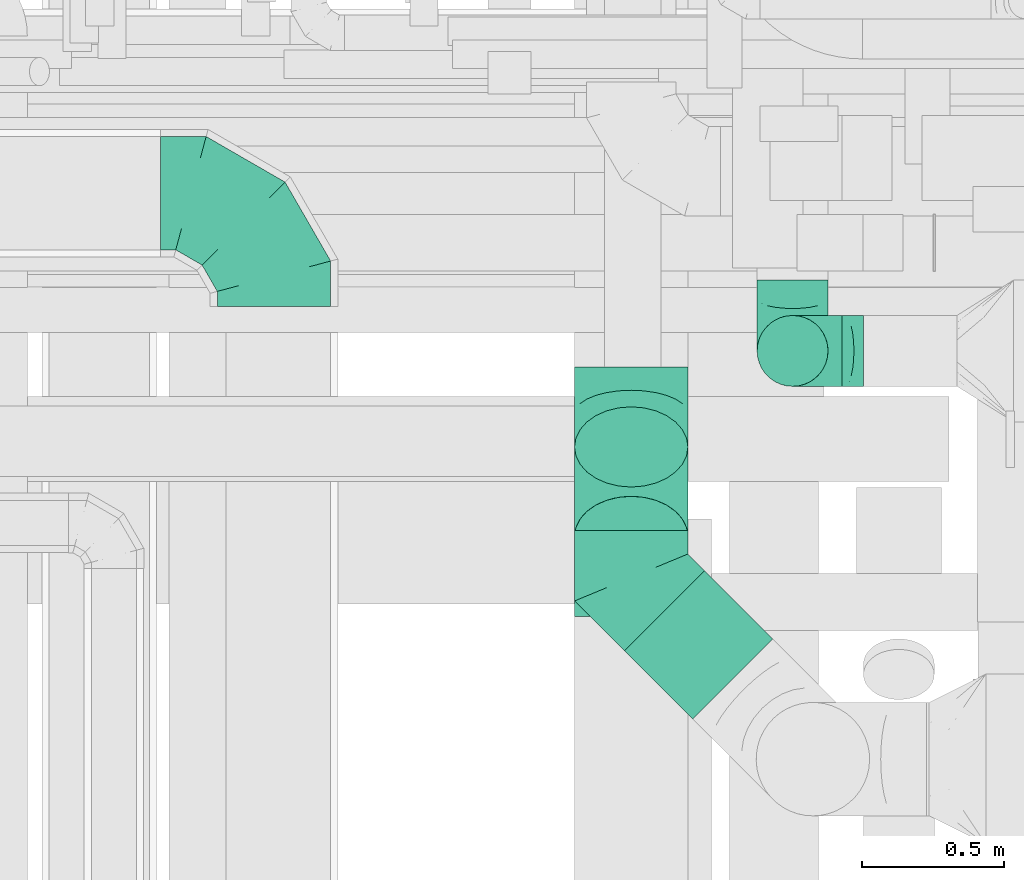
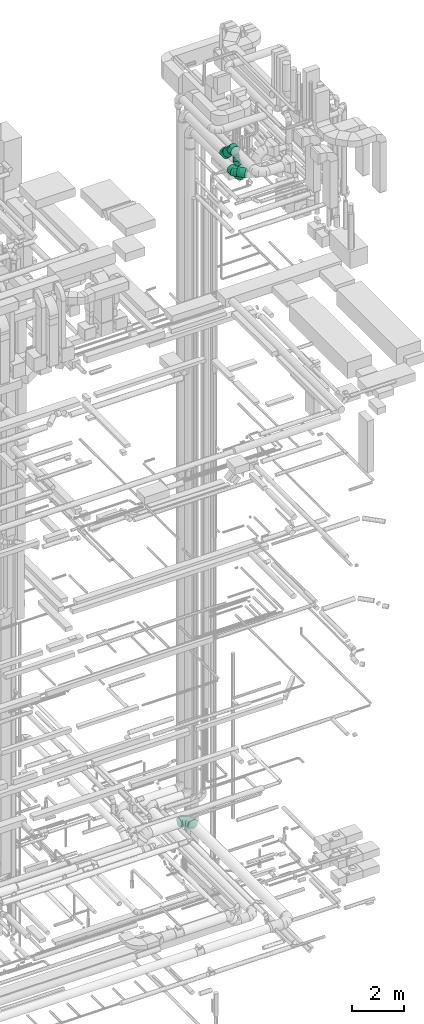
# One storey, part 257 of 337: 7 flow fittings, 4 flow segments.
"""IFC2X3 building model written with IfcOpenShell, lengths in millimetres."""

from ifc_helpers import new_model, entity, si_unit, converted_unit, derived_unit, direction, frame, origin, origin_2d_with_axis, place, context, subcontext, project, spatial, circle, extrude, faceted_brep, source, transform, mapped, material, type_object, type_shapes, element, save


model = new_model("IFC2X3")

# Units and contexts
model_context = context("Model", 3, precision=0.01, world=origin(), true_north=direction((6.12303176911189e-17, 1.0)))
body_context = subcontext(model_context, "Body", "Model", "MODEL_VIEW")
ifc_project = project(units=[si_unit("LENGTHUNIT", "METRE", prefix="MILLI"), si_unit("AREAUNIT", "SQUARE_METRE"), si_unit("VOLUMEUNIT", "CUBIC_METRE"), converted_unit("PLANEANGLEUNIT", "DEGREE", entity("IfcRatioMeasure", 0.0174532925199433), si_unit("PLANEANGLEUNIT", "RADIAN"), dimensions=[0, 0, 0, 0, 0, 0, 0]), si_unit("MASSUNIT", "GRAM", prefix="KILO"), derived_unit("MASSDENSITYUNIT", [(si_unit("MASSUNIT", "GRAM", prefix="KILO"), 1), (si_unit("LENGTHUNIT", "METRE"), -3)]), derived_unit("MOMENTOFINERTIAUNIT", [(si_unit("LENGTHUNIT", "METRE"), 4)]), si_unit("TIMEUNIT", "SECOND"), si_unit("FREQUENCYUNIT", "HERTZ"), si_unit("THERMODYNAMICTEMPERATUREUNIT", "DEGREE_CELSIUS"), derived_unit("THERMALTRANSMITTANCEUNIT", [(si_unit("MASSUNIT", "GRAM", prefix="KILO"), 1), (si_unit("THERMODYNAMICTEMPERATUREUNIT", "KELVIN"), -1), (si_unit("TIMEUNIT", "SECOND"), -3)]), derived_unit("VOLUMETRICFLOWRATEUNIT", [(si_unit("LENGTHUNIT", "METRE"), 3), (si_unit("TIMEUNIT", "SECOND"), -1)]), derived_unit("MASSFLOWRATEUNIT", [(si_unit("MASSUNIT", "GRAM", prefix="KILO"), 1), (si_unit("TIMEUNIT", "SECOND"), -1)]), derived_unit("ROTATIONALFREQUENCYUNIT", [(si_unit("TIMEUNIT", "SECOND"), -1)]), si_unit("ELECTRICCURRENTUNIT", "AMPERE"), si_unit("ELECTRICVOLTAGEUNIT", "VOLT"), si_unit("POWERUNIT", "WATT"), si_unit("FORCEUNIT", "NEWTON", prefix="KILO"), si_unit("ILLUMINANCEUNIT", "LUX"), si_unit("LUMINOUSFLUXUNIT", "LUMEN"), si_unit("LUMINOUSINTENSITYUNIT", "CANDELA"), derived_unit("USERDEFINED", [(si_unit("MASSUNIT", "GRAM", prefix="KILO"), -1), (si_unit("LENGTHUNIT", "METRE"), -2), (si_unit("TIMEUNIT", "SECOND"), 3), (si_unit("LUMINOUSFLUXUNIT", "LUMEN"), 1)]), derived_unit("LINEARVELOCITYUNIT", [(si_unit("LENGTHUNIT", "METRE"), 1), (si_unit("TIMEUNIT", "SECOND"), -1)]), si_unit("PRESSUREUNIT", "PASCAL"), derived_unit("USERDEFINED", [(si_unit("LENGTHUNIT", "METRE"), -2), (si_unit("MASSUNIT", "GRAM", prefix="KILO"), 1), (si_unit("TIMEUNIT", "SECOND"), -2)]), derived_unit("LINEARFORCEUNIT", [(si_unit("MASSUNIT", "GRAM", prefix="KILO"), 1), (si_unit("LENGTHUNIT", "METRE"), 1), (si_unit("TIMEUNIT", "SECOND"), -2), (si_unit("LENGTHUNIT", "METRE"), -1)]), derived_unit("PLANARFORCEUNIT", [(si_unit("MASSUNIT", "GRAM", prefix="KILO"), 1), (si_unit("LENGTHUNIT", "METRE"), 1), (si_unit("TIMEUNIT", "SECOND"), -2), (si_unit("LENGTHUNIT", "METRE"), -2)])], contexts=[model_context])

# Site, building, storey
site_placement = place(None, origin())
site = spatial("IfcSite", under=ifc_project, at=site_placement, CompositionType="ELEMENT")
building_placement = place(site_placement, origin())
building = spatial("IfcBuilding", under=site, at=building_placement, CompositionType="ELEMENT")
storey_placement = place(building_placement, origin())
storey = spatial("IfcBuildingStorey", under=building, at=storey_placement, CompositionType="ELEMENT", Elevation=0.0)

# Flow segments
duct_segment_type = type_object("IfcDuctSegmentType", PredefinedType="NOTDEFINED")
flow_segment_1_placement = place(storey_placement, frame((67357.46, 8396.28, 34974.14)))
element("IfcFlowSegment", 1, at=flow_segment_1_placement, inside=storey, type_object=duct_segment_type, context=body_context, shape_type="SweptSolid", body=[
    extrude(circle(Radius=200.0, at=origin_2d_with_axis()), frame((201.6, 143.02, 458.7), z_axis=(0.0, 0.707106781186547, -0.707106781186548), x_axis=(-1.0, 0.0, 0.0)), (0.0, 0.0, 1.0), 446.44660940674),
])
flow_segment_2_placement = place(storey_placement, frame((67533.19, 7893.55, 34318.4)))
element("IfcFlowSegment", 2, at=flow_segment_2_placement, inside=storey, type_object=duct_segment_type, context=body_context, shape_type="SweptSolid", body=[
    extrude(circle(Radius=200.0, at=origin_2d_with_axis()), frame((143.02, 383.81, 201.6), z_axis=(0.707106781186543, -0.707106781186552, 0.0), x_axis=(0.707106781186552, 0.707106781186543, 0.0)), (0.0, 0.0, 1.0), 340.528682794611),
])
flow_segment_3_placement = place(storey_placement, frame((68001.5, 9067.1, 33750.0)))
element("IfcFlowSegment", 3, at=flow_segment_3_placement, inside=storey, type_object=duct_segment_type, context=body_context, shape_type="SweptSolid", body=[
    extrude(circle(Radius=125.0, at=origin_2d_with_axis()), frame((126.6, 126.6, 0.0), z_axis=(0.0, 0.0, 1.0), x_axis=(0.0, 1.0, 0.0)), (0.0, 0.0, 1.0), 275.000000000041),
])
flow_segment_4_placement = place(storey_placement, frame((68001.5, 9067.1, 34375.0)))
element("IfcFlowSegment", 4, at=flow_segment_4_placement, inside=storey, type_object=duct_segment_type, context=body_context, shape_type="SweptSolid", body=[
    extrude(circle(Radius=125.0, at=origin_2d_with_axis()), frame((126.6, 126.6, 0.0)), (0.0, 0.0, 1.0), 174.999999999995),
])

# Flow fittings
ifc_material = material()
duct_fitting_type_1 = type_object("IfcDuctFittingType", PredefinedType="NOTDEFINED", material=ifc_material)
shared_shape_1 = source(origin(), body_context, "Body", "Brep", [
    faceted_brep([(-250.0, 0.0, -125.0), (-250.0, -32.35, -120.74), (-250.0, -62.5, -108.25), (-250.0, -88.39, -88.39), (-250.0, -108.25, -62.5), (-250.0, -120.74, -32.35), (-250.0, -125.0, 0.0), (-250.0, -120.74, 32.35), (-250.0, -108.25, 62.5), (-250.0, -88.39, 88.39), (-250.0, -62.5, 108.25), (-250.0, -32.35, 120.74), (-250.0, 0.0, 125.0), (-250.0, 32.35, 120.74), (-250.0, 62.5, 108.25), (-250.0, 88.39, 88.39), (-250.0, 108.25, 62.5), (-250.0, 120.74, 32.35), (-250.0, 125.0, 0.0), (-250.0, 120.74, -32.35), (-250.0, 108.25, -62.5), (-250.0, 88.39, -88.39), (-250.0, 62.5, -108.25), (-250.0, 32.35, -120.74), (-191.68, 32.35, 120.74), (-199.76, 62.5, 108.25), (-183.01, 0.0, 125.0), (-206.7, 88.39, 88.39), (-215.37, 120.74, 32.35), (-216.51, 125.0, 0.0), (-212.02, 108.25, 62.5), (-212.02, 108.25, -62.5), (-206.7, 88.39, -88.39), (-215.37, 120.74, -32.35), (-191.68, 32.35, -120.74), (-183.01, 0.0, -125.0), (-199.76, 62.5, -108.25), (-174.34, -32.35, -120.74), (-166.27, -62.5, -108.25), (-159.33, -88.39, -88.39), (-154.01, -108.25, -62.5), (-150.66, -120.74, -32.35), (-149.52, -125.0, 0.0), (-150.66, -120.74, 32.35), (-154.01, -108.25, 62.5), (-159.33, -88.39, 88.39), (-166.27, -62.5, 108.25), (-174.34, -32.35, 120.74), (-90.67, 90.67, 120.74), (-112.74, 112.74, 108.25), (-66.99, 66.99, 125.0), (-131.69, 131.69, 88.39), (-146.23, 146.23, 62.5), (-155.38, 155.38, 32.35), (-158.49, 158.49, 0.0), (-155.38, 155.38, -32.35), (-146.23, 146.23, -62.5), (-131.69, 131.69, -88.39), (-90.67, 90.67, -120.74), (-66.99, 66.99, -125.0), (-112.74, 112.74, -108.25), (-43.3, 43.3, -120.74), (-21.23, 21.23, -108.25), (-2.28, 2.28, -88.39), (12.26, -12.26, -62.5), (21.4, -21.4, -32.35), (24.52, -24.52, 0.0), (21.4, -21.4, 32.35), (12.26, -12.26, 62.5), (-2.28, 2.28, 88.39), (-21.23, 21.23, 108.25), (-43.3, 43.3, 120.74), (-32.35, 191.68, 120.74), (-62.5, 199.76, 108.25), (0.0, 183.01, 125.0), (-88.39, 206.7, 88.39), (-108.25, 212.02, 62.5), (-120.74, 215.37, 32.35), (-125.0, 216.51, 0.0), (-120.74, 215.37, -32.35), (-108.25, 212.02, -62.5), (-88.39, 206.7, -88.39), (-32.35, 191.68, -120.74), (0.0, 183.01, -125.0), (-62.5, 199.76, -108.25), (32.35, 174.34, -120.74), (62.5, 166.27, -108.25), (88.39, 159.33, -88.39), (108.25, 154.01, -62.5), (120.74, 150.66, -32.35), (125.0, 149.52, 0.0), (120.74, 150.66, 32.35), (108.25, 154.01, 62.5), (88.39, 159.33, 88.39), (62.5, 166.27, 108.25), (32.35, 174.34, 120.74), (-32.35, 250.0, -120.74), (-62.5, 250.0, -108.25), (-88.39, 250.0, -88.39), (-108.25, 250.0, -62.5), (-120.74, 250.0, -32.35), (-125.0, 250.0, 0.0), (-120.74, 250.0, 32.35), (-108.25, 250.0, 62.5), (-88.39, 250.0, 88.39), (-62.5, 250.0, 108.25), (-32.35, 250.0, 120.74), (0.0, 250.0, 125.0), (32.35, 250.0, 120.74), (62.5, 250.0, 108.25), (88.39, 250.0, 88.39), (108.25, 250.0, 62.5), (120.74, 250.0, 32.35), (125.0, 250.0, 0.0), (120.74, 250.0, -32.35), (108.25, 250.0, -62.5), (88.39, 250.0, -88.39), (62.5, 250.0, -108.25), (32.35, 250.0, -120.74), (0.0, 250.0, -125.0)], [[[0, 1, 2, 3, 4, 5, 6, 7, 8, 9, 10, 11, 12, 13, 14, 15, 16, 17, 18, 19, 20, 21, 22, 23]], [[24, 25, 14, 13]], [[26, 24, 13, 12]], [[14, 25, 27, 15]], [[28, 29, 18, 17]], [[30, 28, 17, 16]], [[15, 27, 30, 16]], [[20, 31, 32, 21]], [[33, 31, 20, 19]], [[18, 29, 33, 19]], [[34, 35, 0, 23]], [[36, 34, 23, 22]], [[21, 32, 36, 22]], [[1, 0, 35, 37]], [[2, 1, 37, 38]], [[38, 39, 3, 2]], [[5, 4, 40, 41]], [[6, 5, 41, 42]], [[39, 40, 4, 3]], [[6, 42, 43, 7]], [[7, 43, 44, 8]], [[8, 44, 45, 9]], [[9, 45, 46, 10]], [[10, 46, 47, 11]], [[26, 12, 11, 47]], [[48, 49, 25, 24]], [[50, 48, 24, 26]], [[27, 25, 49, 51]], [[52, 53, 28, 30]], [[51, 52, 30, 27]], [[29, 28, 53, 54]], [[55, 56, 31, 33]], [[54, 55, 33, 29]], [[32, 31, 56, 57]], [[58, 59, 35, 34]], [[60, 58, 34, 36]], [[57, 60, 36, 32]], [[37, 35, 59, 61]], [[38, 37, 61, 62]], [[39, 38, 62, 63]], [[41, 40, 64, 65]], [[42, 41, 65, 66]], [[63, 64, 40, 39]], [[43, 42, 66, 67]], [[44, 43, 67, 68]], [[68, 69, 45, 44]], [[46, 45, 69, 70]], [[47, 46, 70, 71]], [[26, 47, 71, 50]], [[72, 73, 49, 48]], [[74, 72, 48, 50]], [[51, 49, 73, 75]], [[76, 77, 53, 52]], [[75, 76, 52, 51]], [[54, 53, 77, 78]], [[79, 80, 56, 55]], [[78, 79, 55, 54]], [[57, 56, 80, 81]], [[82, 83, 59, 58]], [[84, 82, 58, 60]], [[81, 84, 60, 57]], [[61, 59, 83, 85]], [[62, 61, 85, 86]], [[63, 62, 86, 87]], [[65, 64, 88, 89]], [[66, 65, 89, 90]], [[87, 88, 64, 63]], [[67, 66, 90, 91]], [[68, 67, 91, 92]], [[92, 93, 69, 68]], [[70, 69, 93, 94]], [[71, 70, 94, 95]], [[50, 71, 95, 74]], [[96, 97, 98, 99, 100, 101, 102, 103, 104, 105, 106, 107, 108, 109, 110, 111, 112, 113, 114, 115, 116, 117, 118, 119]], [[72, 74, 107, 106]], [[73, 72, 106, 105]], [[75, 73, 105, 104]], [[77, 76, 103, 102]], [[78, 77, 102, 101]], [[75, 104, 103, 76]], [[78, 101, 100, 79]], [[79, 100, 99, 80]], [[80, 99, 98, 81]], [[84, 97, 96, 82]], [[82, 96, 119, 83]], [[84, 81, 98, 97]], [[83, 119, 118, 85]], [[85, 118, 117, 86]], [[116, 87, 86, 117]], [[88, 115, 114, 89]], [[89, 114, 113, 90]], [[115, 88, 87, 116]], [[91, 90, 113, 112]], [[92, 91, 112, 111]], [[111, 110, 93, 92]], [[95, 94, 109, 108]], [[74, 95, 108, 107]], [[110, 109, 94, 93]]]),
])
type_shapes(duct_fitting_type_1, [shared_shape_1])
for number, where, z_axis, x_axis in (
    (5, (68128.1, 9193.7, 33500.0), (0.0, 1.0, 0.0), (-1.0, 0.0, 0.0)),
    (6, (68128.1, 9193.7, 34800.0), (-1.0, 0.0, 0.0), (0.0, 0.0, 1.0)),
):
    element("IfcFlowFitting", number, at=place(storey_placement, frame(where, z_axis=z_axis, x_axis=x_axis)), inside=storey, type_object=duct_fitting_type_1, material=ifc_material, context=body_context, shape_type="MappedRepresentation", body=[
        mapped(shared_shape_1, transform((0.0, 0.0, 0.0), scale=1.0)),
    ])
duct_fitting_type_2 = type_object("IfcDuctFittingType", PredefinedType="NOTDEFINED", material=ifc_material)
shared_shape_2 = source(origin(), body_context, "Body", "Brep", [
    faceted_brep([(-165.69, 0.0, -200.0), (-165.69, -44.5, -194.99), (-165.69, -86.78, -180.19), (-165.69, -124.7, -156.37), (-165.69, -156.37, -124.7), (-165.69, -180.19, -86.78), (-165.69, -194.99, -44.5), (-165.69, -200.0, 0.0), (-165.69, -194.99, 44.5), (-165.69, -180.19, 86.78), (-165.69, -156.37, 124.7), (-165.69, -124.7, 156.37), (-165.69, -86.78, 180.19), (-165.69, -44.5, 194.99), (-165.69, 0.0, 200.0), (-165.69, 44.5, 194.99), (-165.69, 86.78, 180.19), (-165.69, 124.7, 156.37), (-165.69, 156.37, 124.7), (-165.69, 180.19, 86.78), (-165.69, 194.99, 44.5), (-165.69, 200.0, 0.0), (-165.69, 194.99, -44.5), (-165.69, 180.19, -86.78), (-165.69, 156.37, -124.7), (-165.69, 124.7, -156.37), (-165.69, 86.78, -180.19), (-165.69, 44.5, -194.99), (0.0, 0.0, 200.0), (-18.43, 44.5, 194.99), (-35.94, 86.78, 180.19), (-51.65, 124.7, 156.37), (-64.77, 156.37, 124.7), (-74.64, 180.19, 86.78), (-80.77, 194.99, 44.5), (-82.84, 200.0, 0.0), (-80.77, 194.99, -44.5), (-74.64, 180.19, -86.78), (-64.77, 156.37, -124.7), (-51.65, 124.7, -156.37), (-35.94, 86.78, -180.19), (-18.43, 44.5, -194.99), (0.0, 0.0, -200.0), (18.43, -44.5, -194.99), (35.94, -86.78, -180.19), (51.65, -124.7, -156.37), (64.77, -156.37, -124.7), (74.64, -180.19, -86.78), (80.77, -194.99, -44.5), (82.84, -200.0, 0.0), (80.77, -194.99, 44.5), (74.64, -180.19, 86.78), (64.77, -156.37, 124.7), (51.65, -124.7, 156.37), (35.94, -86.78, 180.19), (18.43, -44.5, 194.99), (117.16, 117.16, 200.0), (85.69, 148.63, 194.99), (55.8, 178.52, 180.19), (28.98, 205.33, 156.37), (6.59, 227.72, 124.7), (-10.26, 244.57, 86.78), (-20.72, 255.03, 44.5), (-24.26, 258.58, 0.0), (-20.72, 255.03, -44.5), (-10.26, 244.57, -86.78), (6.59, 227.72, -124.7), (28.98, 205.33, -156.37), (55.8, 178.52, -180.19), (85.69, 148.63, -194.99), (117.16, 117.16, -200.0), (148.63, 85.69, -194.99), (178.52, 55.8, -180.19), (205.33, 28.98, -156.37), (227.72, 6.59, -124.7), (244.57, -10.26, -86.78), (255.03, -20.72, -44.5), (258.58, -24.26, 0.0), (255.03, -20.72, 44.5), (244.57, -10.26, 86.78), (227.72, 6.59, 124.7), (205.33, 28.98, 156.37), (178.52, 55.8, 180.19), (148.63, 85.69, 194.99)], [[[0, 1, 2, 3, 4, 5, 6, 7, 8, 9, 10, 11, 12, 13, 14, 15, 16, 17, 18, 19, 20, 21, 22, 23, 24, 25, 26, 27]], [[28, 29, 15, 14]], [[30, 31, 17, 16]], [[29, 30, 16, 15]], [[31, 32, 18, 17]], [[32, 33, 19, 18]], [[34, 35, 21, 20]], [[33, 34, 20, 19]], [[35, 36, 22, 21]], [[37, 38, 24, 23]], [[36, 37, 23, 22]], [[38, 39, 25, 24]], [[39, 40, 26, 25]], [[41, 42, 0, 27]], [[40, 41, 27, 26]], [[1, 0, 42, 43]], [[43, 44, 2, 1]], [[45, 3, 2, 44]], [[45, 46, 4, 3]], [[5, 4, 46, 47]], [[47, 48, 6, 5]], [[49, 7, 6, 48]], [[7, 49, 50, 8]], [[8, 50, 51, 9]], [[9, 51, 52, 10]], [[52, 53, 11, 10]], [[11, 53, 54, 12]], [[12, 54, 55, 13]], [[13, 55, 28, 14]], [[29, 28, 56, 57]], [[30, 29, 57, 58]], [[31, 30, 58, 59]], [[59, 60, 32, 31]], [[33, 32, 60, 61]], [[34, 33, 61, 62]], [[35, 34, 62, 63]], [[63, 64, 36, 35]], [[65, 66, 38, 37]], [[64, 65, 37, 36]], [[66, 67, 39, 38]], [[39, 67, 68, 40]], [[40, 68, 69, 41]], [[41, 69, 70, 42]], [[42, 70, 71, 43]], [[43, 71, 72, 44]], [[44, 72, 73, 45]], [[73, 74, 46, 45]], [[46, 74, 75, 47]], [[47, 75, 76, 48]], [[48, 76, 77, 49]], [[50, 49, 77, 78]], [[51, 50, 78, 79]], [[52, 51, 79, 80]], [[80, 81, 53, 52]], [[54, 53, 81, 82]], [[55, 54, 82, 83]], [[28, 55, 83, 56]], [[69, 68, 67, 66, 65, 64, 63, 62, 61, 60, 59, 58, 57, 56, 83, 82, 81, 80, 79, 78, 77, 76, 75, 74, 73, 72, 71, 70]]]),
])
type_shapes(duct_fitting_type_2, [shared_shape_2])
for number, where, z_axis, x_axis in (
    (7, (67559.05, 8422.14, 35550.0), (1.0, 0.0, 0.0), (0.0, -0.707106781186521, 0.707106781186574)),
    (8, (67559.05, 8972.14, 35000.0), (1.0, 0.0, 0.0), (0.0, 0.707106781186522, -0.707106781186573)),
    (9, (67559.05, 8394.51, 34520.0), (0.0, 0.0, 1.0), (0.0, -1.0, 0.0)),
):
    element("IfcFlowFitting", number, at=place(storey_placement, frame(where, z_axis=z_axis, x_axis=x_axis)), inside=storey, type_object=duct_fitting_type_2, material=ifc_material, context=body_context, shape_type="MappedRepresentation", body=[
        mapped(shared_shape_2, transform((0.0, 0.0, 0.0), scale=1.0)),
    ])
duct_fitting_type_3 = type_object("IfcDuctFittingType", PredefinedType="NOTDEFINED", material=ifc_material)
shared_shape_3 = source(origin(), body_context, "Body", "Brep", [
    faceted_brep([(-400.0, 0.0, -200.0), (-400.0, -44.5, -194.99), (-400.0, -86.78, -180.19), (-400.0, -124.7, -156.37), (-400.0, -156.37, -124.7), (-400.0, -180.19, -86.78), (-400.0, -194.99, -44.5), (-400.0, -200.0, 0.0), (-400.0, -194.99, 44.5), (-400.0, -180.19, 86.78), (-400.0, -156.37, 124.7), (-400.0, -124.7, 156.37), (-400.0, -86.78, 180.19), (-400.0, -44.5, 194.99), (-400.0, 0.0, 200.0), (-400.0, 44.5, 194.99), (-400.0, 86.78, 180.19), (-400.0, 124.7, 156.37), (-400.0, 156.37, 124.7), (-400.0, 180.19, 86.78), (-400.0, 194.99, 44.5), (-400.0, 200.0, 0.0), (-400.0, 194.99, -44.5), (-400.0, 180.19, -86.78), (-400.0, 156.37, -124.7), (-400.0, 124.7, -156.37), (-400.0, 86.78, -180.19), (-400.0, 44.5, -194.99), (-292.82, 0.0, 200.0), (-304.75, 44.5, 194.99), (-316.07, 86.78, 180.19), (-326.23, 124.7, 156.37), (-334.72, 156.37, 124.7), (-341.1, 180.19, 86.78), (-345.07, 194.99, 44.5), (-346.41, 200.0, 0.0), (-345.07, 194.99, -44.5), (-341.1, 180.19, -86.78), (-334.72, 156.37, -124.7), (-326.23, 124.7, -156.37), (-316.07, 86.78, -180.19), (-304.75, 44.5, -194.99), (-292.82, 0.0, -200.0), (-280.9, -44.5, -194.99), (-269.57, -86.78, -180.19), (-259.41, -124.7, -156.37), (-250.92, -156.37, -124.7), (-244.54, -180.19, -86.78), (-240.57, -194.99, -44.5), (-239.23, -200.0, 0.0), (-240.57, -194.99, 44.5), (-244.54, -180.19, 86.78), (-250.92, -156.37, 124.7), (-259.41, -124.7, 156.37), (-269.57, -86.78, 180.19), (-280.9, -44.5, 194.99), (-107.18, 107.18, 200.0), (-139.76, 139.76, 194.99), (-170.7, 170.7, 180.19), (-198.46, 198.46, 156.37), (-221.65, 221.65, 124.7), (-239.09, 239.09, 86.78), (-249.92, 249.92, 44.5), (-253.59, 253.59, 0.0), (-249.92, 249.92, -44.5), (-239.09, 239.09, -86.78), (-221.65, 221.65, -124.7), (-198.46, 198.46, -156.37), (-170.7, 170.7, -180.19), (-139.76, 139.76, -194.99), (-107.18, 107.18, -200.0), (-74.6, 74.6, -194.99), (-43.65, 43.65, -180.19), (-15.89, 15.89, -156.37), (7.29, -7.29, -124.7), (24.73, -24.73, -86.78), (35.56, -35.56, -44.5), (39.23, -39.23, 0.0), (35.56, -35.56, 44.5), (24.73, -24.73, 86.78), (7.29, -7.29, 124.7), (-15.89, 15.89, 156.37), (-43.65, 43.65, 180.19), (-74.6, 74.6, 194.99), (0.0, 292.82, 200.0), (-44.5, 304.75, 194.99), (-86.78, 316.07, 180.19), (-124.7, 326.23, 156.37), (-156.37, 334.72, 124.7), (-180.19, 341.1, 86.78), (-194.99, 345.07, 44.5), (-200.0, 346.41, 0.0), (-194.99, 345.07, -44.5), (-180.19, 341.1, -86.78), (-156.37, 334.72, -124.7), (-124.7, 326.23, -156.37), (-86.78, 316.07, -180.19), (-44.5, 304.75, -194.99), (0.0, 292.82, -200.0), (44.5, 280.9, -194.99), (86.78, 269.57, -180.19), (124.7, 259.41, -156.37), (156.37, 250.92, -124.7), (180.19, 244.54, -86.78), (194.99, 240.57, -44.5), (200.0, 239.23, 0.0), (194.99, 240.57, 44.5), (180.19, 244.54, 86.78), (156.37, 250.92, 124.7), (124.7, 259.41, 156.37), (86.78, 269.57, 180.19), (44.5, 280.9, 194.99), (-44.5, 400.0, -194.99), (-86.78, 400.0, -180.19), (-124.7, 400.0, -156.37), (-156.37, 400.0, -124.7), (-180.19, 400.0, -86.78), (-194.99, 400.0, -44.5), (-200.0, 400.0, 0.0), (-194.99, 400.0, 44.5), (-180.19, 400.0, 86.78), (-156.37, 400.0, 124.7), (-124.7, 400.0, 156.37), (-86.78, 400.0, 180.19), (-44.5, 400.0, 194.99), (0.0, 400.0, 200.0), (44.5, 400.0, 194.99), (86.78, 400.0, 180.19), (124.7, 400.0, 156.37), (156.37, 400.0, 124.7), (180.19, 400.0, 86.78), (194.99, 400.0, 44.5), (200.0, 400.0, 0.0), (194.99, 400.0, -44.5), (180.19, 400.0, -86.78), (156.37, 400.0, -124.7), (124.7, 400.0, -156.37), (86.78, 400.0, -180.19), (44.5, 400.0, -194.99), (0.0, 400.0, -200.0)], [[[0, 1, 2, 3, 4, 5, 6, 7, 8, 9, 10, 11, 12, 13, 14, 15, 16, 17, 18, 19, 20, 21, 22, 23, 24, 25, 26, 27]], [[28, 29, 15, 14]], [[30, 31, 17, 16]], [[29, 30, 16, 15]], [[31, 32, 18, 17]], [[32, 33, 19, 18]], [[34, 35, 21, 20]], [[33, 34, 20, 19]], [[35, 36, 22, 21]], [[37, 38, 24, 23]], [[36, 37, 23, 22]], [[38, 39, 25, 24]], [[39, 40, 26, 25]], [[41, 42, 0, 27]], [[40, 41, 27, 26]], [[1, 0, 42, 43]], [[43, 44, 2, 1]], [[45, 3, 2, 44]], [[45, 46, 4, 3]], [[5, 4, 46, 47]], [[47, 48, 6, 5]], [[49, 7, 6, 48]], [[7, 49, 50, 8]], [[8, 50, 51, 9]], [[9, 51, 52, 10]], [[52, 53, 11, 10]], [[11, 53, 54, 12]], [[12, 54, 55, 13]], [[13, 55, 28, 14]], [[56, 57, 29, 28]], [[58, 59, 31, 30]], [[57, 58, 30, 29]], [[59, 60, 32, 31]], [[60, 61, 33, 32]], [[62, 63, 35, 34]], [[61, 62, 34, 33]], [[63, 64, 36, 35]], [[65, 66, 38, 37]], [[64, 65, 37, 36]], [[66, 67, 39, 38]], [[67, 68, 40, 39]], [[69, 70, 42, 41]], [[68, 69, 41, 40]], [[43, 42, 70, 71]], [[71, 72, 44, 43]], [[73, 45, 44, 72]], [[73, 74, 46, 45]], [[47, 46, 74, 75]], [[75, 76, 48, 47]], [[77, 49, 48, 76]], [[50, 49, 77, 78]], [[51, 50, 78, 79]], [[52, 51, 79, 80]], [[80, 81, 53, 52]], [[54, 53, 81, 82]], [[55, 54, 82, 83]], [[28, 55, 83, 56]], [[84, 85, 57, 56]], [[86, 87, 59, 58]], [[85, 86, 58, 57]], [[87, 88, 60, 59]], [[88, 89, 61, 60]], [[90, 91, 63, 62]], [[89, 90, 62, 61]], [[91, 92, 64, 63]], [[93, 94, 66, 65]], [[92, 93, 65, 64]], [[94, 95, 67, 66]], [[95, 96, 68, 67]], [[97, 98, 70, 69]], [[96, 97, 69, 68]], [[71, 70, 98, 99]], [[99, 100, 72, 71]], [[101, 73, 72, 100]], [[101, 102, 74, 73]], [[75, 74, 102, 103]], [[103, 104, 76, 75]], [[105, 77, 76, 104]], [[78, 77, 105, 106]], [[79, 78, 106, 107]], [[80, 79, 107, 108]], [[108, 109, 81, 80]], [[82, 81, 109, 110]], [[83, 82, 110, 111]], [[56, 83, 111, 84]], [[112, 113, 114, 115, 116, 117, 118, 119, 120, 121, 122, 123, 124, 125, 126, 127, 128, 129, 130, 131, 132, 133, 134, 135, 136, 137, 138, 139]], [[85, 84, 125, 124]], [[86, 85, 124, 123]], [[87, 86, 123, 122]], [[122, 121, 88, 87]], [[89, 88, 121, 120]], [[90, 89, 120, 119]], [[91, 90, 119, 118]], [[91, 118, 117, 92]], [[92, 117, 116, 93]], [[93, 116, 115, 94]], [[115, 114, 95, 94]], [[95, 114, 113, 96]], [[96, 113, 112, 97]], [[97, 112, 139, 98]], [[98, 139, 138, 99]], [[99, 138, 137, 100]], [[100, 137, 136, 101]], [[136, 135, 102, 101]], [[102, 135, 134, 103]], [[103, 134, 133, 104]], [[104, 133, 132, 105]], [[106, 105, 132, 131]], [[107, 106, 131, 130]], [[108, 107, 130, 129]], [[129, 128, 109, 108]], [[110, 109, 128, 127]], [[111, 110, 127, 126]], [[84, 111, 126, 125]]]),
])
type_shapes(duct_fitting_type_3, [shared_shape_3])
flow_fitting_1_placement = place(storey_placement, frame((66298.97, 9750.0, 3500.0), z_axis=(0.0, 0.0, 1.0), x_axis=(0.0, 1.0, 0.0)))
element("IfcFlowFitting", 10, at=flow_fitting_1_placement, inside=storey, type_object=duct_fitting_type_3, material=ifc_material, context=body_context, shape_type="MappedRepresentation", body=[
    mapped(shared_shape_3, transform((0.0, 0.0, 0.0), scale=1.0)),
])
duct_fitting_type_4 = type_object("IfcDuctFittingType", PredefinedType="NOTDEFINED", material=ifc_material)
shared_shape_4 = source(origin(), body_context, "Body", "Brep", [
    faceted_brep([(22.44, -22.44, -122.97), (175.0, 0.0, -125.0), (175.0, -32.35, -120.74), (175.0, -62.5, -108.25), (75.83, -75.83, -99.37), (65.72, -65.72, -106.33), (175.0, -88.39, -88.39), (55.24, -55.24, -112.13), (11.24, -11.24, -124.49), (0.0, 0.0, -125.0), (-11.24, -11.24, -124.49), (-175.0, 0.0, -125.0), (44.49, -44.49, -116.81), (33.54, -33.54, -120.42), (175.0, -108.25, -62.5), (102.86, -102.86, -71.03), (175.0, -120.74, -32.35), (116.36, -116.36, -45.66), (175.0, -114.5, -47.43), (123.99, -123.99, -15.84), (175.0, -125.0, 0.0), (125.0, -125.0, 0.0), (-123.99, -123.99, -15.84), (-125.0, -125.0, 0.0), (-175.0, -125.0, 0.0), (175.0, -122.87, -16.18), (110.21, -110.21, -58.98), (121.05, -121.05, -31.19), (94.55, -94.55, -81.76), (85.49, -85.49, -91.2), (123.99, -123.99, 15.84), (-123.99, -123.99, 15.84), (175.0, -114.5, 47.43), (175.0, -108.25, 62.5), (110.21, -110.21, 58.98), (175.0, -120.74, 32.35), (121.05, -121.05, 31.19), (175.0, -122.87, 16.18), (102.86, -102.86, 71.03), (175.0, -88.39, 88.39), (116.36, -116.36, 45.66), (94.55, -94.55, 81.76), (85.49, -85.49, 91.2), (75.83, -75.83, 99.37), (65.72, -65.72, 106.33), (175.0, -62.5, 108.25), (55.24, -55.24, 112.13), (175.0, -32.35, 120.74), (22.44, -22.44, 122.97), (175.0, 0.0, 125.0), (44.49, -44.49, 116.81), (33.54, -33.54, 120.42), (11.24, -11.24, 124.49), (0.0, 0.0, 125.0), (-11.24, -11.24, 124.49), (-175.0, 0.0, 125.0), (32.35, -175.0, -120.74), (62.5, -175.0, -108.25), (88.39, -175.0, -88.39), (108.25, -175.0, -62.5), (114.5, -175.0, -47.43), (120.74, -175.0, -32.35), (122.87, -175.0, -16.18), (125.0, -175.0, 0.0), (122.87, -175.0, 16.18), (120.74, -175.0, 32.35), (114.5, -175.0, 47.43), (108.25, -175.0, 62.5), (88.39, -175.0, 88.39), (62.5, -175.0, 108.25), (32.35, -175.0, 120.74), (0.0, -175.0, 125.0), (-32.35, -175.0, 120.74), (-62.5, -175.0, 108.25), (-88.39, -175.0, 88.39), (-108.25, -175.0, 62.5), (-114.5, -175.0, 47.43), (-120.74, -175.0, 32.35), (-122.87, -175.0, 16.18), (-125.0, -175.0, 0.0), (-122.87, -175.0, -16.18), (-120.74, -175.0, -32.35), (-114.5, -175.0, -47.43), (-108.25, -175.0, -62.5), (-88.39, -175.0, -88.39), (-62.5, -175.0, -108.25), (-32.35, -175.0, -120.74), (0.0, -175.0, -125.0), (-22.44, -22.44, -122.97), (-75.83, -75.83, -99.37), (-65.72, -65.72, -106.33), (-55.24, -55.24, -112.13), (-44.49, -44.49, -116.81), (-33.54, -33.54, -120.42), (-102.86, -102.86, -71.03), (-116.36, -116.36, -45.66), (-110.21, -110.21, -58.98), (-121.05, -121.05, -31.19), (-94.55, -94.55, -81.76), (-85.49, -85.49, -91.2), (-110.21, -110.21, 58.98), (-121.05, -121.05, 31.19), (-102.86, -102.86, 71.03), (-116.36, -116.36, 45.66), (-94.55, -94.55, 81.76), (-85.49, -85.49, 91.2), (-75.83, -75.83, 99.37), (-65.72, -65.72, 106.33), (-55.24, -55.24, 112.13), (-22.44, -22.44, 122.97), (-44.49, -44.49, 116.81), (-33.54, -33.54, 120.42), (-175.0, -32.35, -120.74), (-175.0, -62.5, -108.25), (-175.0, -88.39, -88.39), (-175.0, -108.25, -62.5), (-175.0, -114.5, -47.43), (-175.0, -120.74, -32.35), (-175.0, -122.87, -16.18), (-175.0, -122.87, 16.18), (-175.0, -120.74, 32.35), (-175.0, -114.5, 47.43), (-175.0, -108.25, 62.5), (-175.0, -88.39, 88.39), (-175.0, -62.5, 108.25), (-175.0, -32.35, 120.74), (-175.0, 32.35, 120.74), (-175.0, 62.5, 108.25), (-175.0, 88.39, 88.39), (-175.0, 108.25, 62.5), (-175.0, 120.74, 32.35), (-175.0, 125.0, 0.0), (-175.0, 120.74, -32.35), (-175.0, 108.25, -62.5), (-175.0, 88.39, -88.39), (-175.0, 62.5, -108.25), (-175.0, 32.35, -120.74), (175.0, 32.35, -120.74), (175.0, 62.5, -108.25), (175.0, 88.39, -88.39), (175.0, 108.25, -62.5), (175.0, 120.74, -32.35), (175.0, 125.0, 0.0), (175.0, 120.74, 32.35), (175.0, 108.25, 62.5), (175.0, 88.39, 88.39), (175.0, 62.5, 108.25), (175.0, 32.35, 120.74)], [[[0, 1, 2]], [[3, 4, 5]], [[4, 3, 6]], [[2, 3, 7]], [[5, 7, 3]], [[8, 9, 1]], [[9, 10, 11]], [[0, 8, 1]], [[12, 13, 2]], [[7, 12, 2]], [[0, 2, 13]], [[14, 15, 6]], [[16, 17, 18]], [[19, 20, 21]], [[22, 23, 24]], [[20, 19, 25]], [[26, 18, 17]], [[27, 16, 25]], [[28, 29, 6]], [[15, 28, 6]], [[27, 25, 19]], [[26, 14, 18]], [[27, 17, 16]], [[15, 14, 26]], [[6, 29, 4]], [[30, 21, 20]], [[23, 31, 24]], [[32, 33, 34]], [[35, 36, 37]], [[38, 33, 39]], [[40, 35, 32]], [[30, 37, 36]], [[40, 36, 35]], [[38, 34, 33]], [[41, 38, 39]], [[32, 34, 40]], [[30, 20, 37]], [[39, 42, 41]], [[42, 39, 43]], [[44, 43, 45]], [[46, 45, 47]], [[45, 46, 44]], [[39, 45, 43]], [[48, 47, 49]], [[50, 46, 47]], [[51, 50, 47]], [[52, 48, 49]], [[53, 52, 49]], [[54, 53, 55]], [[51, 47, 48]], [[56, 57, 58, 59, 60, 61, 62, 63, 64, 65, 66, 67, 68, 69, 70, 71, 72, 73, 74, 75, 76, 77, 78, 79, 80, 81, 82, 83, 84, 85, 86, 87]], [[48, 71, 70]], [[69, 43, 44]], [[43, 69, 68]], [[70, 69, 46]], [[44, 46, 69]], [[52, 53, 71]], [[48, 52, 71]], [[50, 51, 70]], [[46, 50, 70]], [[48, 70, 51]], [[67, 38, 68]], [[65, 40, 66]], [[30, 63, 21]], [[63, 30, 64]], [[34, 66, 40]], [[36, 65, 64]], [[41, 42, 68]], [[38, 41, 68]], [[36, 64, 30]], [[34, 67, 66]], [[36, 40, 65]], [[38, 67, 34]], [[68, 42, 43]], [[19, 21, 63]], [[60, 59, 26]], [[62, 61, 27]], [[15, 59, 58]], [[17, 61, 60]], [[19, 62, 27]], [[17, 27, 61]], [[15, 26, 59]], [[28, 15, 58]], [[60, 26, 17]], [[19, 63, 62]], [[58, 29, 28]], [[29, 58, 4]], [[5, 4, 57]], [[7, 57, 56]], [[57, 7, 5]], [[58, 57, 4]], [[0, 56, 87]], [[12, 7, 56]], [[13, 12, 56]], [[8, 0, 87]], [[9, 8, 87]], [[13, 56, 0]], [[88, 87, 86]], [[85, 89, 90]], [[89, 85, 84]], [[86, 85, 91]], [[90, 91, 85]], [[10, 9, 87]], [[88, 10, 87]], [[92, 93, 86]], [[91, 92, 86]], [[88, 86, 93]], [[83, 94, 84]], [[81, 95, 82]], [[22, 79, 23]], [[79, 22, 80]], [[96, 82, 95]], [[97, 81, 80]], [[98, 99, 84]], [[94, 98, 84]], [[97, 80, 22]], [[96, 83, 82]], [[97, 95, 81]], [[94, 83, 96]], [[84, 99, 89]], [[31, 23, 79]], [[76, 75, 100]], [[77, 101, 78]], [[102, 75, 74]], [[103, 77, 76]], [[31, 78, 101]], [[103, 101, 77]], [[102, 100, 75]], [[104, 102, 74]], [[76, 100, 103]], [[31, 79, 78]], [[74, 105, 104]], [[105, 74, 106]], [[107, 106, 73]], [[108, 73, 72]], [[73, 108, 107]], [[74, 73, 106]], [[109, 72, 71]], [[110, 108, 72]], [[111, 110, 72]], [[54, 109, 71]], [[53, 54, 71]], [[111, 72, 109]], [[11, 112, 113, 114, 115, 116, 117, 118, 24, 119, 120, 121, 122, 123, 124, 125, 55, 126, 127, 128, 129, 130, 131, 132, 133, 134, 135, 136]], [[137, 138, 139, 140, 141, 142, 143, 144, 145, 146, 147, 49, 47, 45, 39, 33, 32, 35, 37, 20, 25, 16, 18, 14, 6, 3, 2, 1]], [[53, 49, 147, 126, 55]], [[127, 126, 147, 146]], [[146, 145, 128, 127]], [[129, 128, 145, 144]], [[130, 129, 144, 143]], [[131, 130, 143, 142]], [[132, 131, 142, 141]], [[133, 132, 141, 140]], [[140, 139, 134, 133]], [[135, 134, 139, 138]], [[136, 135, 138, 137]], [[9, 11, 136, 137, 1]], [[93, 92, 112]], [[88, 93, 112]], [[10, 88, 11]], [[88, 112, 11]], [[112, 92, 91]], [[112, 91, 113]], [[113, 90, 89]], [[90, 113, 91]], [[113, 89, 114]], [[98, 94, 114]], [[99, 98, 114]], [[95, 117, 116]], [[95, 97, 117]], [[95, 116, 96]], [[94, 96, 115]], [[116, 115, 96]], [[115, 114, 94]], [[22, 24, 118]], [[118, 117, 97]], [[118, 97, 22]], [[99, 114, 89]], [[101, 103, 120]], [[102, 104, 123]], [[100, 102, 122]], [[101, 119, 31]], [[100, 122, 121]], [[100, 121, 103]], [[24, 31, 119]], [[120, 119, 101]], [[103, 121, 120]], [[102, 123, 122]], [[104, 105, 123]], [[110, 111, 125]], [[108, 110, 125]], [[109, 54, 55]], [[111, 109, 125]], [[106, 107, 124]], [[106, 124, 123]], [[108, 124, 107]], [[108, 125, 124]], [[109, 55, 125]], [[106, 123, 105]]]),
])
type_shapes(duct_fitting_type_4, [shared_shape_4])
flow_fitting_2_placement = place(storey_placement, frame((68128.1, 9193.7, 34200.0), z_axis=(0.0, 1.0, 0.0), x_axis=(0.0, 0.0, -1.0)))
element("IfcFlowFitting", 11, at=flow_fitting_2_placement, inside=storey, type_object=duct_fitting_type_4, material=ifc_material, context=body_context, shape_type="MappedRepresentation", body=[
    mapped(shared_shape_4, transform((0.0, 0.0, 0.0), scale=1.0)),
])

save(model, "model.ifc")
